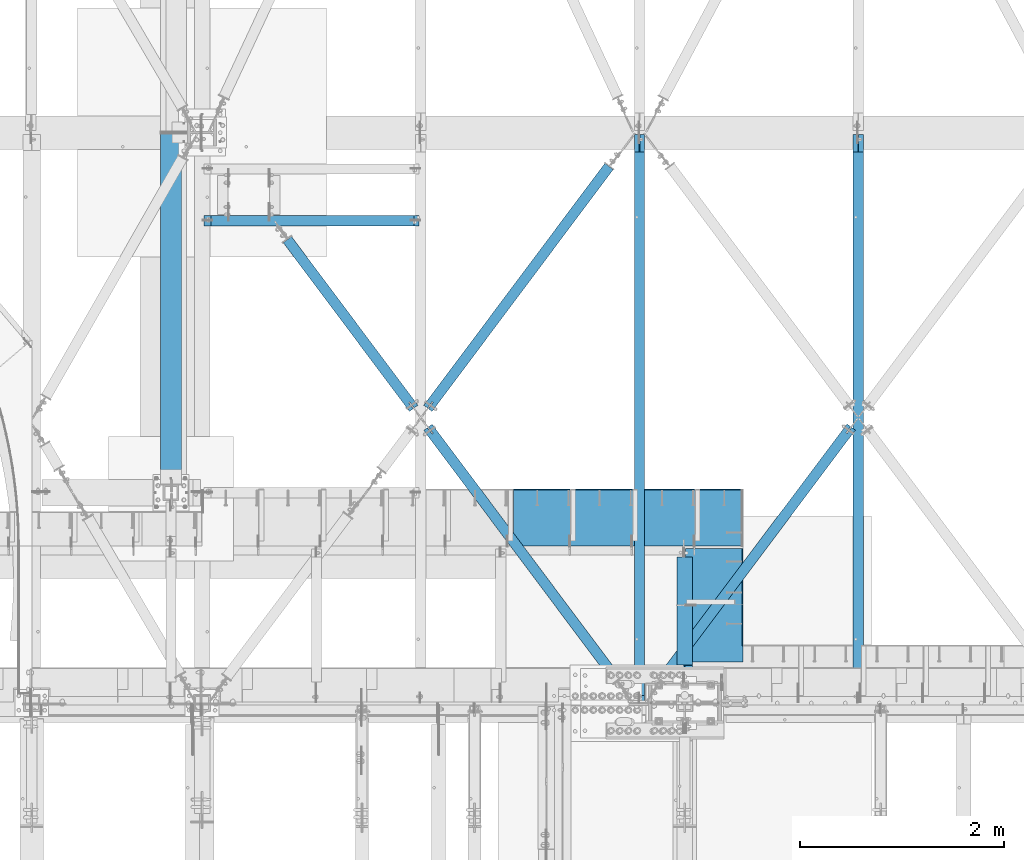
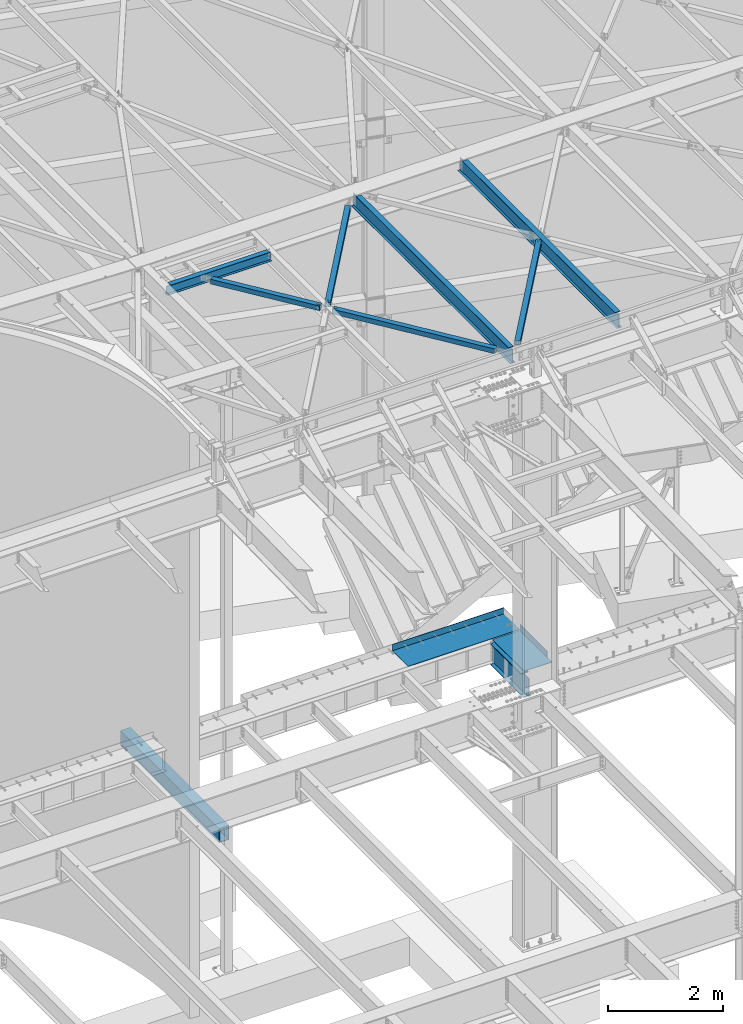
# One storey, part 1151 of 1763: 11 beams, 10 elements without a shape of their own.
"""IFC2X3 building model written with IfcOpenShell, lengths in millimetres."""

import ifcopenshell
import ifcopenshell.guid

model = None  # the IFC model being written
_history = None  # IfcOwnerHistory: only IFC2X3 demands one
_inside = {}  # id of a spatial element -> (the spatial element, [elements in it])
_under = {}  # id of a project, library or spatial element -> (it, [spatial elements below it])
_declared = {}  # id of a project -> (the project, [libraries it declares])
_typed = {}  # id of a type object -> (the type object, [elements of that type])
_made_of = {}  # id of a material, layer set ... -> (it, [elements and type objects made of it])


def new_model(schema):
    """Start an empty IFC model of exactly this schema.

    Asked for "IFC4X3", IfcOpenShell would pick the latest addendum, in which some entities
    have other attributes; the version numbers below select the first issue.
    IFC2X3 requires an IfcOwnerHistory on every rooted entity: one is made here for all.
    """
    global model, _history
    if schema == "IFC4X3":
        model = ifcopenshell.file(schema_version=(4, 3, 0, 0))
    else:
        model = ifcopenshell.file(schema=schema)
    _inside.clear()
    _under.clear()
    _declared.clear()
    _typed.clear()
    _made_of.clear()
    _history = None
    if model.schema == "IFC2X3":
        org = make("IfcOrganization", Name="unknown")
        user = make(
            "IfcPersonAndOrganization",
            ThePerson=make("IfcPerson", FamilyName="unknown"),
            TheOrganization=org,
        )
        app = make(
            "IfcApplication",
            ApplicationDeveloper=org,
            Version="unknown",
            ApplicationFullName="unknown",
            ApplicationIdentifier="unknown",
        )
        _history = make(
            "IfcOwnerHistory",
            OwningUser=user,
            OwningApplication=app,
            ChangeAction="ADDED",
            CreationDate=0,
        )
    return model


def make(cls, **values):
    """One entity of the class cls with the attributes given. An attribute that is None is left unset."""
    return model.create_entity(
        cls, **{name: value for name, value in values.items() if value is not None}
    )


def rooted(cls, **values):
    """An entity with a GlobalId (a new one), such as an element, a storey or a relation."""
    return make(cls, GlobalId=ifcopenshell.guid.new(), OwnerHistory=_history, **values)


def si_unit(unit_type, name, prefix=None):
    """IfcSIUnit, for example si_unit("LENGTHUNIT", "METRE", prefix="MILLI")."""
    return make("IfcSIUnit", UnitType=unit_type, Prefix=prefix, Name=name)


def assignment(units):
    """IfcUnitAssignment: the units of a project."""
    return None if units is None else make("IfcUnitAssignment", Units=units)


def point(xyz):
    """IfcCartesianPoint."""
    return None if xyz is None else make("IfcCartesianPoint", Coordinates=xyz)


def direction(xyz):
    """IfcDirection."""
    return None if xyz is None else make("IfcDirection", DirectionRatios=xyz)


def frame(location, z_axis=None, x_axis=None):
    """IfcAxis2Placement3D, a coordinate frame: its origin and axes. An axis left out is left unset."""
    return make(
        "IfcAxis2Placement3D",
        Location=point(location),
        Axis=direction(z_axis),
        RefDirection=direction(x_axis),
    )


def origin_with_axes():
    """The frame at (0, 0, 0) with the z axis (0, 0, 1) and the x axis (1, 0, 0) written out."""
    return frame((0.0, 0.0, 0.0), z_axis=(0.0, 0.0, 1.0), x_axis=(1.0, 0.0, 0.0))


def place(relative_to, where):
    """IfcLocalPlacement: puts the frame where relative to a parent placement (None: the world)."""
    return make(
        "IfcLocalPlacement", PlacementRelTo=relative_to, RelativePlacement=where
    )


def context(
    kind, dimensions, precision=None, world=None, true_north=None, identifier=None
):
    """IfcGeometricRepresentationContext, for example the 3D "Model" context."""
    return make(
        "IfcGeometricRepresentationContext",
        ContextIdentifier=identifier,
        ContextType=kind,
        CoordinateSpaceDimension=dimensions,
        Precision=precision,
        WorldCoordinateSystem=world,
        TrueNorth=true_north,
    )


def subcontext(parent, identifier, kind, view, scale=None):
    """IfcGeometricRepresentationSubContext, for example "Body" below "Model"."""
    return make(
        "IfcGeometricRepresentationSubContext",
        ContextIdentifier=identifier,
        ContextType=kind,
        ParentContext=parent,
        TargetScale=scale,
        TargetView=view,
    )


def project(units=None, contexts=None):
    """IfcProject with its units and contexts."""
    return rooted(
        "IfcProject",
        Name="project",
        RepresentationContexts=contexts,
        UnitsInContext=assignment(units),
    )


def spatial(cls, under=None, at=None, **own):
    """A site, building, storey or space (cls), placed at a placement, below another one or the project."""
    s = rooted(cls, ObjectPlacement=at, **own)
    if under is not None:
        _under.setdefault(under.id(), (under, []))[1].append(s)
    return s


def faces_of(points, faces, orient=None, outer=None):
    """IfcFace entities. A face is a list of loops; a loop is a list of indices into points, from 0.

    orient and outer hold one flag for each loop. By default every Orientation is true, the
    first loop of a face is its IfcFaceOuterBound and the others are IfcFaceBound.
    """
    made = []
    for i, loops in enumerate(faces):
        bounds = []
        for j, loop in enumerate(loops):
            is_outer = j == 0 if outer is None else outer[i][j]
            bounds.append(
                make(
                    "IfcFaceOuterBound" if is_outer else "IfcFaceBound",
                    Bound=make("IfcPolyLoop", Polygon=[points[k] for k in loop]),
                    Orientation=True if orient is None else orient[i][j],
                )
            )
        made.append(make("IfcFace", Bounds=bounds))
    return made


def faceted_brep(points, faces, orient=None, outer=None, voids=None):
    """IfcFacetedBrep: a solid bounded by flat faces; with voids (closed shells), ...WithVoids."""
    shared = [point(p) for p in points]
    hull = make("IfcClosedShell", CfsFaces=faces_of(shared, faces, orient, outer))
    if voids is None:
        return make("IfcFacetedBrep", Outer=hull)
    return make(
        "IfcFacetedBrepWithVoids",
        Outer=hull,
        Voids=[
            make(cls, CfsFaces=faces_of(shared, fs, o, b)) for cls, fs, o, b in voids
        ],
    )


def shape(context_of_items, identifier, shape_type, items):
    """IfcShapeRepresentation: the items that make up one representation, for example the "Body"."""
    return make(
        "IfcShapeRepresentation",
        ContextOfItems=context_of_items,
        RepresentationIdentifier=identifier,
        RepresentationType=shape_type,
        Items=items,
    )


def material(Name=None, Category=None):
    """IfcMaterial."""
    return make("IfcMaterial", Name=Name, Category=Category)


def made_of(thing, what):
    """Note that an element or type object is made of a material, layer set ...; save() writes the relation."""
    if what is not None:
        _made_of.setdefault(what.id(), (what, []))[1].append(thing)
    return thing


def type_object(cls, material=None, **own):
    """A type object (cls), such as IfcWallType, which elements share."""
    return made_of(rooted(cls, **own), material)


def element(
    cls,
    number,
    at=None,
    inside=None,
    cuts=None,
    type_object=None,
    material=None,
    context=None,
    identifier="Body",
    shape_type=None,
    held_by="IfcProductDefinitionShape",
    body=None,
    shapes=None,
    **own,
):
    """One element of the class cls, such as IfcWall. Its Tag is "e" and its number.

    at: its placement. inside: the storey or other place that contains it. cuts: it is an
    opening in that element (IfcRelVoidsElement). A single representation is given by context,
    identifier, shape_type and body (its items); several are given by shapes. held_by: the class
    of the entity that holds the representations. save() writes the other relations.
    """
    e = rooted(cls, Tag="e%d" % number, ObjectPlacement=at, **own)
    if body is not None:
        shapes = [shape(context, identifier, shape_type, body)]
    if shapes is not None:
        e.Representation = make(held_by, Representations=shapes)
    if inside is not None:
        _inside.setdefault(inside.id(), (inside, []))[1].append(e)
    if cuts is not None:
        rooted(
            "IfcRelVoidsElement", RelatingBuildingElement=cuts, RelatedOpeningElement=e
        )
    if type_object is not None:
        _typed.setdefault(type_object.id(), (type_object, []))[1].append(e)
    return made_of(e, material)


def aggregate(whole, parts):
    """IfcRelAggregates: a whole, such as a stair, and the parts it consists of."""
    return rooted("IfcRelAggregates", RelatingObject=whole, RelatedObjects=parts)


def save(model, path):
    """Write the relations noted so far, then the file.

    IfcRelAggregates (storeys below a building ...), IfcRelContainedInSpatialStructure (elements
    in a storey), IfcRelDefinesByType, IfcRelAssociatesMaterial and IfcRelDeclares: one each for
    every whole, place, type object, material and project.
    """
    for whole, parts in _under.values():
        aggregate(whole, parts)
    for where, things in _inside.values():
        rooted(
            "IfcRelContainedInSpatialStructure",
            RelatedElements=things,
            RelatingStructure=where,
        )
    for kind, things in _typed.values():
        rooted("IfcRelDefinesByType", RelatedObjects=things, RelatingType=kind)
    for what, things in _made_of.values():
        rooted("IfcRelAssociatesMaterial", RelatedObjects=things, RelatingMaterial=what)
    for by, libraries in _declared.values():
        rooted("IfcRelDeclares", RelatingContext=by, RelatedDefinitions=libraries)
    model.write(path)


model = new_model("IFC2X3")

# Units and contexts
model_context = context("Model", 3, precision=1e-05, world=origin_with_axes())
body_context = subcontext(model_context, "Body", "Model", "MODEL_VIEW")
ifc_project = project(units=[si_unit("LENGTHUNIT", "METRE", prefix="MILLI"), si_unit("AREAUNIT", "SQUARE_METRE"), si_unit("VOLUMEUNIT", "CUBIC_METRE"), si_unit("MASSUNIT", "GRAM", prefix="KILO"), si_unit("TIMEUNIT", "SECOND"), si_unit("PLANEANGLEUNIT", "RADIAN"), si_unit("SOLIDANGLEUNIT", "STERADIAN"), si_unit("THERMODYNAMICTEMPERATUREUNIT", "DEGREE_CELSIUS"), si_unit("LUMINOUSINTENSITYUNIT", "LUMEN")], contexts=[model_context])

# Site, building, storey
site_placement = place(None, origin_with_axes())
site = spatial("IfcSite", under=ifc_project, at=site_placement, CompositionType="ELEMENT")
building_placement = place(site_placement, origin_with_axes())
building = spatial("IfcBuilding", under=site, at=building_placement, Name="Undefined", CompositionType="ELEMENT")
storey_placement = place(building_placement, origin_with_axes())
storey = spatial("IfcBuildingStorey", under=building, at=storey_placement, Name="Undefined", CompositionType="ELEMENT", Elevation=0.0)

# Assembly, beam
assembly_1_placement = place(storey_placement, origin_with_axes())
assembly_1 = element("IfcElementAssembly", 1, at=assembly_1_placement, inside=storey, Name="BEAM", AssemblyPlace="NOTDEFINED", PredefinedType="RIGID_FRAME")
ifc_material_1 = material(Name="STEEL/A992")
beam_type_1 = type_object("IfcBeamType", Name="W8X10", PredefinedType="NOTDEFINED")
beam_1_placement = place(assembly_1_placement, frame((-39672.2896174484, 56838.8499999993, 12345.9875), z_axis=(0.0, 0.0, 1.0), x_axis=(1.0, 0.0, 0.0)))
beam_1 = element("IfcBeam", 2, at=beam_1_placement, type_object=beam_type_1, material=ifc_material_1, Name="BEAM", ObjectType="W8X10", context=body_context, shape_type="Brep", body=[
    faceted_brep([(2073.27499999999, -50.8000000000029, 100.012500000001), (2073.27499999999, -50.8000000000029, 95.25), (2073.27499999999, -2.38124999999854, 95.25), (2073.27499999999, -2.38124999999854, 93.4024995803829), (2073.27499999999, 2.38124999999854, 93.4024995803829), (2073.27499999999, 2.38124999999854, 95.25), (2073.27499999999, 50.8000000000029, 95.25), (2073.27499999999, 50.8000000000029, 100.012500000001), (2074.24172992259, -2.38124999999854, 88.5424200623365), (2074.24172992259, 2.38124999999854, 88.5424200623365), (2076.99474382306, -2.38124999999854, 84.4222435941829), (2076.99474382306, 2.38124999999854, 84.4222435941829), (2081.11492029121, -2.38124999999854, 81.6692296937053), (2081.11492029121, 2.38124999999854, 81.6692296937053), (2085.97499980926, -2.38124999999854, 80.7024997711178), (2085.97499980926, 2.38124999999854, 80.7024997711178), (2124.075, -2.38124999999854, 80.7024997711178), (2124.075, 2.38124999999854, 80.7024997711178), (88.8999969557553, -50.8000000000029, 100.012500000001), (88.8999969557553, 50.8000000000029, 100.012500000001), (88.8999969557553, 50.8000000000029, 95.25), (88.8999969557553, 2.38124999999854, 95.25), (88.8999969557553, 2.38124999999854, 84.1374998092651), (88.8999969557553, -2.38124999999854, 84.1374998092651), (88.8999969557553, -2.38124999999854, 95.25), (88.8999969557553, -50.8000000000029, 95.25), (87.9332670331642, 2.38124999999854, 79.2774202912187), (87.9332670331642, -2.38124999999854, 79.2774202912187), (85.1802531326903, 2.38124999999854, 75.1572438230651), (85.1802531326903, -2.38124999999854, 75.1572438230651), (81.0600766645366, 2.38124999999854, 72.4042299225875), (81.0600766645366, -2.38124999999854, 72.4042299225875), (76.1999971464902, 2.38124999999854, 71.4375), (76.1999971464902, -2.38124999999854, 71.4375), (16.6687500075204, 2.38124999999854, 71.4375), (16.6687500075204, -2.38124999999854, 71.4375), (16.6687500075204, 2.38124999999854, -95.25), (16.6687500075204, 50.8000000000029, -95.25), (16.6687500075204, 50.8000000000029, -100.012500000001), (16.6687500075204, -50.8000000000029, -100.012500000001), (16.6687500075204, -50.8000000000029, -95.25), (16.6687500075204, -2.38124999999854, -95.25), (2124.075, 2.38124999999854, -95.25), (2124.075, 50.8000000000029, -95.25), (2124.075, 50.8000000000029, -100.012500000001), (2124.075, -50.8000000000029, -100.012500000001), (2124.075, -50.8000000000029, -95.25), (2124.075, -2.38124999999854, -95.25)], [[[0, 1, 2, 3, 4, 5, 6, 7]], [[8, 9, 4, 3]], [[10, 11, 9, 8]], [[12, 13, 11, 10]], [[14, 15, 13, 12]], [[16, 17, 15, 14]], [[18, 19, 20, 21, 22, 23, 24, 25]], [[23, 22, 26, 27]], [[27, 26, 28, 29]], [[29, 28, 30, 31]], [[31, 30, 32, 33]], [[33, 32, 34, 35]], [[36, 37, 38, 39, 40, 41, 35, 34]], [[37, 36, 42, 43]], [[38, 37, 43, 44]], [[39, 38, 44, 45]], [[40, 39, 45, 46]], [[41, 40, 46, 47]], [[12, 10, 8, 3, 2, 24, 23, 27, 29, 31, 33, 35, 41, 47, 16, 14]], [[25, 24, 2, 1]], [[18, 25, 1, 0]], [[19, 18, 0, 7]], [[20, 19, 7, 6]], [[21, 20, 6, 5]], [[42, 36, 34, 32, 30, 28, 26, 22, 21, 5, 4, 9, 11, 13, 15, 17]], [[47, 46, 45, 44, 43, 42, 17, 16]]]),
])
aggregate(assembly_1, [beam_1])

assembly_2_placement = place(storey_placement, origin_with_axes())
assembly_2 = element("IfcElementAssembly", 3, at=assembly_2_placement, inside=storey, Name="H. BRACE", AssemblyPlace="NOTDEFINED", PredefinedType="RIGID_FRAME")
ifc_material_2 = material()
beam_type_2 = type_object("IfcBeamType", Name="HSS4X4X3/8", PredefinedType="NOTDEFINED")
beam_2_placement = place(assembly_2_placement, frame((-37532.3396174715, 54911.6249997678, 12371.3875), z_axis=(0.0, 0.0, 1.0), x_axis=(-0.599271154042197, 0.800546116056367, 0.0)))
beam_2 = element("IfcBeam", 4, at=beam_2_placement, type_object=beam_type_2, material=ifc_material_2, Name="H. BRACE", ObjectType="HSS4X4X3/8", context=body_context, shape_type="Brep", body=[
    faceted_brep([(115.54492887533, 6.35000628506759, 50.7999999999993), (115.54492887533, 6.35000628506759, 41.2749999999996), (192.63464721787, 6.35000000986702, 41.2749999999996), (192.63464721787, 6.35000000986702, 50.7999999999993), (192.634646184073, -6.34999999016281, 50.7999999999993), (192.634646184073, -6.34999999016281, 41.2749999999996), (115.544928875344, -6.34999371496588, 41.2749999999996), (115.544928875344, -6.34999371496588, 50.7999999999993), (115.54492887533, 6.35000628506759, -41.2749999999996), (115.54492887533, 6.35000628506759, -50.7999999999993), (192.63464721787, 6.35000000986702, -50.7999999999993), (192.63464721787, 6.35000000986702, -41.2749999999996), (192.634646184073, -6.34999999016281, -41.2749999999996), (192.634646184073, -6.34999999016281, -50.7999999999993), (115.544928875344, -6.34999371496588, -50.7999999999993), (115.544928875344, -6.34999371496588, -41.2749999999996), (115.544928544976, -41.2750000003798, -41.2749999999996), (115.544928544976, -41.2750000003798, 41.2749999999996), (2179.00881947795, -41.2749999953026, 41.2749999999996), (2179.00881947795, -41.2749999953026, -41.2749999999996), (115.544928544969, 50.7999999998938, -50.7999999999993), (2179.00881947795, 50.8000000049637, -50.7999999999993), (2179.00881947795, -50.7999999953367, -50.7999999999993), (115.544928544976, -50.8000000004031, -50.7999999999993), (115.544928544976, -50.8000000004031, 50.7999999999993), (2179.00881947795, -50.7999999953367, 50.7999999999993), (115.544928544965, 41.2749999998705, 41.2749999999996), (2179.00881947795, 41.2750000049368, 41.2749999999996), (115.544928544965, 41.2749999998705, -41.2749999999996), (2179.00881947795, 41.2750000049368, -41.2749999999996), (2179.00881947795, 50.8000000049637, 50.7999999999993), (115.544928544969, 50.7999999998938, 50.7999999999993)], [[[0, 1, 2, 3]], [[4, 5, 6, 7]], [[3, 2, 5, 4]], [[8, 9, 10, 11]], [[12, 13, 14, 15]], [[11, 10, 13, 12]], [[16, 17, 18, 19]], [[9, 20, 21, 22, 23, 14, 13, 10]], [[24, 23, 22, 25]], [[17, 16, 15, 14, 23, 24, 7, 6]], [[1, 26, 27, 18, 17, 6, 5, 2]], [[26, 28, 29, 27]], [[25, 22, 21, 30], [18, 27, 29, 19]], [[20, 31, 30, 21]], [[24, 25, 30, 31, 0, 3, 4, 7]], [[31, 20, 9, 8, 28, 26, 1, 0]], [[16, 19, 29, 28, 8, 11, 12, 15]]]),
])
aggregate(assembly_2, [beam_2])

assembly_3_placement = place(storey_placement, origin_with_axes())
assembly_3 = element("IfcElementAssembly", 5, at=assembly_3_placement, inside=storey, Name="H. BRACE", AssemblyPlace="NOTDEFINED", PredefinedType="RIGID_FRAME")
beam_3_placement = place(assembly_3_placement, frame((-33252.4396174507, 54913.6789185365, 12371.3875), z_axis=(0.0, 0.0, 1.0), x_axis=(-0.600137979714526, -0.799896496619511, 0.0)))
beam_3 = element("IfcBeam", 6, at=beam_3_placement, type_object=beam_type_2, material=ifc_material_2, Name="H. BRACE", ObjectType="HSS4X4X3/8", context=body_context, shape_type="Brep", body=[
    faceted_brep([(115.323049640105, 6.35036732612934, 50.7999999999993), (115.323049640105, 6.35036732612934, 41.2749999999996), (192.613788202219, 6.35004939841019, 41.2749999999996), (192.613788202219, 6.35004939841019, 50.7999999999993), (192.613735962041, -6.34995060151414, 50.7999999999993), (192.613735962041, -6.34995060151414, 41.2749999999996), (115.323049640094, -6.34963267402054, 41.2749999999996), (115.323049640094, -6.34963267402054, 50.7999999999993), (115.323049640105, 6.35036732612934, -41.2749999999996), (115.323049640105, 6.35036732612934, -50.7999999999993), (192.613788202219, 6.35004939841019, -50.7999999999993), (192.613788202219, 6.35004939841019, -41.2749999999996), (192.613735962041, -6.34995060151414, -41.2749999999996), (192.613735962041, -6.34995060151414, -50.7999999999993), (115.323049640094, -6.34963267402054, -50.7999999999993), (115.323049640094, -6.34963267402054, -41.2749999999996), (115.323049640101, -41.2750000002925, -41.2749999999996), (115.323049640101, -41.2750000002925, 41.2749999999996), (3211.35244293956, -41.2750000086453, 41.2749999999996), (3211.35244293956, -41.2750000086453, -41.2749999999996), (115.323049640101, 50.7999999996464, -50.7999999999993), (3211.35244293955, 50.7999999912863, -50.7999999999993), (3211.35244293955, -50.8000000086395, -50.7999999999993), (115.323049640101, -50.8000000002867, -50.7999999999993), (115.323049640101, -50.8000000002867, 50.7999999999993), (3211.35244293955, -50.8000000086395, 50.7999999999993), (115.323049640101, 41.2749999996522, 41.2749999999996), (3211.35244293955, 41.2749999912994, 41.2749999999996), (115.323049640101, 41.2749999996522, -41.2749999999996), (3211.35244293955, 41.2749999912994, -41.2749999999996), (3211.35244293955, 50.7999999912863, 50.7999999999993), (115.323049640101, 50.7999999996464, 50.7999999999993)], [[[0, 1, 2, 3]], [[4, 5, 6, 7]], [[3, 2, 5, 4]], [[8, 9, 10, 11]], [[12, 13, 14, 15]], [[11, 10, 13, 12]], [[16, 17, 18, 19]], [[9, 20, 21, 22, 23, 14, 13, 10]], [[24, 23, 22, 25]], [[17, 16, 15, 14, 23, 24, 7, 6]], [[1, 26, 27, 18, 17, 6, 5, 2]], [[26, 28, 29, 27]], [[25, 22, 21, 30], [18, 27, 29, 19]], [[20, 31, 30, 21]], [[24, 25, 30, 31, 0, 3, 4, 7]], [[31, 20, 9, 8, 28, 26, 1, 0]], [[16, 19, 29, 28, 8, 11, 12, 15]]]),
])
aggregate(assembly_3, [beam_3])

assembly_4_placement = place(storey_placement, origin_with_axes())
assembly_4 = element("IfcElementAssembly", 7, at=assembly_4_placement, inside=storey, Name="H. BRACE", AssemblyPlace="NOTDEFINED", PredefinedType="RIGID_FRAME")
beam_4_placement = place(assembly_4_placement, frame((-35443.1896206415, 57702.4499982766, 12371.3875), z_axis=(0.0, 0.0, 1.0), x_axis=(-0.599271154042197, -0.800546116056367, 0.0)))
beam_4 = element("IfcBeam", 8, at=beam_4_placement, type_object=beam_type_2, material=ifc_material_2, Name="H. BRACE", ObjectType="HSS4X4X3/8", context=body_context, shape_type="Brep", body=[
    faceted_brep([(3370.60651739793, 6.35217274886236, 50.7999999999993), (3293.52321707223, 6.35001054574241, 50.7999999999993), (3293.52321707223, 6.35001054574241, 41.2749999999996), (3370.60651739793, 6.35217274886236, 41.2749999999996), (3293.52357330995, -6.34998944934341, 50.7999999999993), (3293.52357330995, -6.34998944934341, 41.2749999999996), (3370.60651739793, -6.34782725620607, 50.7999999999993), (3370.60651739793, -6.34782725620607, 41.2749999999996), (3370.60651739793, 6.35217274886236, -41.2749999999996), (3293.52321707223, 6.35001054574241, -41.2749999999996), (3293.52321707223, 6.35001054574241, -50.7999999999993), (3370.60651739793, 6.35217274886236, -50.7999999999993), (3293.52357330995, -6.34998944934341, -41.2749999999996), (3293.52357330995, -6.34998944934341, -50.7999999999993), (3370.60651739793, -6.34782725620607, -41.2749999999996), (3370.60651739793, -6.34782725620607, -50.7999999999993), (413.146953942767, 41.2749999992084, 41.2749999999996), (413.146953942767, 41.2749999992084, -41.2749999999996), (3370.60651739793, 41.2749999926746, -41.2749999999996), (3370.60651739793, 41.2749999926746, 41.2749999999996), (3370.60651739793, -41.2750000075612, 41.2749999999996), (413.146953942756, -41.2750000010274, 41.2749999999996), (413.146953942756, -41.2750000010274, -41.2749999999996), (3370.60651739793, -41.2750000075612, -41.2749999999996), (413.146953942764, -50.8000000010579, -50.7999999999993), (413.146953942764, -50.8000000010579, 50.7999999999993), (413.14695394276, 50.7999999992317, 50.7999999999993), (413.14695394276, 50.7999999992317, -50.7999999999993), (3370.60651739793, 50.7999999926978, 50.7999999999993), (3370.60651739793, 50.7999999926978, -50.7999999999993), (3370.60651739793, -50.8000000075917, -50.7999999999993), (3370.60651739793, -50.8000000075917, 50.7999999999993)], [[[0, 1, 2, 3]], [[4, 5, 2, 1]], [[6, 7, 5, 4]], [[8, 9, 10, 11]], [[12, 13, 10, 9]], [[14, 15, 13, 12]], [[16, 17, 18, 19]], [[20, 21, 16, 19, 3, 2, 5, 7]], [[22, 21, 20, 23]], [[9, 8, 18, 17, 22, 23, 14, 12]], [[24, 25, 26, 27], [16, 21, 22, 17]], [[27, 26, 28, 29]], [[19, 18, 8, 11, 29, 28, 0, 3]], [[30, 24, 27, 29, 11, 10, 13, 15]], [[25, 24, 30, 31]], [[1, 0, 28, 26, 25, 31, 6, 4]], [[31, 30, 15, 14, 23, 20, 7, 6]]]),
])
aggregate(assembly_4, [beam_4])

assembly_5_placement = place(storey_placement, origin_with_axes())
assembly_5 = element("IfcElementAssembly", 9, at=assembly_5_placement, inside=storey, Name="H. BRACE", AssemblyPlace="NOTDEFINED", PredefinedType="RIGID_FRAME")
beam_5_placement = place(assembly_5_placement, frame((-35443.1896174837, 52120.8000004499, 12371.3875), z_axis=(0.0, 0.0, 1.0), x_axis=(-0.599271154042197, 0.800546116056367, 0.0)))
beam_5 = element("IfcBeam", 10, at=beam_5_placement, type_object=beam_type_2, material=ifc_material_2, Name="H. BRACE", ObjectType="HSS4X4X3/8", context=body_context, shape_type="Brep", body=[
    faceted_brep([(3370.60651701657, 6.34999381892521, 50.7999999999993), (3293.51679972227, 6.35000009411851, 50.7999999999993), (3293.51679972227, 6.35000009411851, 41.2749999999996), (3370.60651701657, 6.34999381892521, 41.2749999999996), (3293.51679868849, -6.34999990591132, 50.7999999999993), (3293.51679868849, -6.34999990591132, 41.2749999999996), (3370.60651701657, -6.35000618111917, 50.7999999999993), (3370.60651701657, -6.35000618111917, 41.2749999999996), (3370.60651701657, 6.34999381892521, -41.2749999999996), (3293.51679972227, 6.35000009411851, -41.2749999999996), (3293.51679972227, 6.35000009411851, -50.7999999999993), (3370.60651701657, 6.34999381892521, -50.7999999999993), (3293.51679868849, -6.34999990591132, -41.2749999999996), (3293.51679868849, -6.34999990591132, -50.7999999999993), (3370.60651701657, -6.35000618111917, -41.2749999999996), (3370.60651701657, -6.35000618111917, -50.7999999999993), (280.170548871072, 41.2750000007491, 41.2749999999996), (280.170548871072, 41.2750000007491, -41.2749999999996), (3370.60651739793, 41.2749999926746, -41.2749999999996), (3370.60651739793, 41.2749999926746, 41.2749999999996), (3370.60651739793, -41.2750000075612, 41.2749999999996), (280.170548871072, -41.274999999494, 41.2749999999996), (280.170548871072, -41.274999999494, -41.2749999999996), (3370.60651739793, -41.2750000075612, -41.2749999999996), (280.17054887108, -50.7999999995172, -50.7999999999993), (280.17054887108, -50.7999999995172, 50.7999999999993), (280.170548871072, 50.8000000007723, 50.7999999999993), (280.170548871072, 50.8000000007723, -50.7999999999993), (3370.60651739793, 50.7999999926978, 50.7999999999993), (3370.60651739793, 50.7999999926978, -50.7999999999993), (3370.60651739793, -50.8000000075917, -50.7999999999993), (3370.60651739793, -50.8000000075917, 50.7999999999993)], [[[0, 1, 2, 3]], [[4, 5, 2, 1]], [[6, 7, 5, 4]], [[8, 9, 10, 11]], [[12, 13, 10, 9]], [[14, 15, 13, 12]], [[16, 17, 18, 19]], [[20, 21, 16, 19, 3, 2, 5, 7]], [[22, 21, 20, 23]], [[9, 8, 18, 17, 22, 23, 14, 12]], [[24, 25, 26, 27], [16, 21, 22, 17]], [[27, 26, 28, 29]], [[19, 18, 8, 11, 29, 28, 0, 3]], [[30, 24, 27, 29, 11, 10, 13, 15]], [[25, 24, 30, 31]], [[1, 0, 28, 26, 25, 31, 6, 4]], [[31, 30, 15, 14, 23, 20, 7, 6]]]),
])
aggregate(assembly_5, [beam_5])

assembly_6_placement = place(storey_placement, origin_with_axes())
assembly_6 = element("IfcElementAssembly", 11, at=assembly_6_placement, inside=storey, Name="BEAM", AssemblyPlace="NOTDEFINED", PredefinedType="RIGID_FRAME")
ifc_material_3 = material(Name="STEEL/A36")
beam_type_3 = type_object("IfcBeamType", PredefinedType="NOTDEFINED")
beam_6_placement = place(assembly_6_placement, frame((-34943.4872736984, 53076.4799995422, 5199.0625), z_axis=(0.0, -1.0, 0.0), x_axis=(1.0, 0.0, 0.0)))
beam_6 = element("IfcBeam", 12, at=beam_6_placement, type_object=beam_type_3, material=ifc_material_3, Name="BENT PLATE", context=body_context, shape_type="Brep", body=[
    faceted_brep([(561.975402832039, 134.937496948242, 396.910991792152), (552.450402832088, 134.937526078659, 396.910561852666), (552.450004716316, 4.76249999999982, 396.910562799247), (561.975004737265, 4.76933441718575, 396.910992738674), (561.975004737265, 4.76933441725305, 555.625), (552.450004716316, 4.76249999999982, 555.625), (0.0, -4.76249999999982, -555.625), (0.0, -4.76249999999982, 555.625), (0.0, 4.76249999999982, 555.625), (0.0, 4.76249999999982, -555.625), (561.974975585945, -4.76249999999982, -555.625), (552.450004716316, 4.76249999999982, -555.625), (552.450402832088, 134.937526078659, -555.625), (561.975402832039, 134.937496948242, -555.625), (561.974975585945, -4.76249999999982, 555.625), (14.5130368310492, 4.76249999999982, 555.625)], [[[0, 1, 2, 3]], [[4, 3, 2, 5]], [[6, 7, 8, 9]], [[10, 6, 9, 11, 12, 13]], [[7, 6, 10, 14]], [[15, 8, 7, 14, 4, 5]], [[9, 8, 15, 5, 2, 11]], [[12, 11, 2, 1]], [[13, 12, 1, 0]], [[14, 10, 13, 0, 3, 4]]]),
])

assembly_7_placement = place(storey_placement, origin_with_axes())
assembly_7 = element("IfcElementAssembly", 13, at=assembly_7_placement, inside=storey, Name="BEAM", AssemblyPlace="NOTDEFINED", PredefinedType="RIGID_FRAME")
beam_type_4 = type_object("IfcBeamType", PredefinedType="NOTDEFINED")
beam_7_placement = place(assembly_7_placement, frame((-35502.7211174484, 53657.5, 5199.0625), z_axis=(1.0, 0.0, 0.0), x_axis=(0.0, 1.0, 0.0)))
beam_7 = element("IfcBeam", 14, at=beam_7_placement, type_object=beam_type_4, material=ifc_material_3, Name="BENT PLATE", context=body_context, shape_type="Brep", body=[
    faceted_brep([(0.0, -4.76249999999982, -1121.5685), (0.0, -4.76249999999982, 1121.5685), (0.0, 4.76249999999982, 1121.5685), (0.0, 4.76249999999982, -1121.5685), (546.100000000006, 4.76249999999982, 1121.5685), (546.100000000006, 4.76249999999982, -1121.5685), (555.625, -4.76249999999982, -1121.5685), (555.625, -4.76249999999982, 1121.5685), (546.100000000006, 134.937496948242, 1121.5685), (546.100000000006, 134.937496948242, -1121.5685), (555.625, 134.937496948242, 1121.5685), (555.625, 134.937496948242, -1121.5685)], [[[0, 1, 2, 3]], [[3, 2, 4, 5]], [[1, 0, 6, 7]], [[5, 4, 8, 9]], [[4, 2, 1, 7, 10, 8]], [[7, 6, 11, 10]], [[6, 0, 3, 5, 9, 11]], [[10, 11, 9, 8]]]),
])
aggregate(assembly_7, [beam_7])

assembly_8_placement = place(storey_placement, origin_with_axes())
assembly_8 = element("IfcElementAssembly", 15, at=assembly_8_placement, inside=storey, Name="BEAM", AssemblyPlace="NOTDEFINED", PredefinedType="RIGID_FRAME")
beam_type_5 = type_object("IfcBeamType", Name="W12X16", PredefinedType="NOTDEFINED")
beam_8_placement = place(assembly_8_placement, frame((-33252.4396174484, 52120.8, 12293.6), z_axis=(0.0, 0.0, 1.0), x_axis=(0.0, 1.0, 0.0)))
beam_8 = element("IfcBeam", 16, at=beam_8_placement, type_object=beam_type_5, material=ifc_material_1, Name="BEAM", ObjectType="W12X16", context=body_context, shape_type="Brep", body=[
    faceted_brep([(63.5000001907174, -3.17499999999927, 126.740001678467), (63.5000001907174, 3.17499999999927, 126.740001678467), (15.8749999999854, 3.17499999999927, 126.740001678467), (15.8749999999854, -3.17499999999927, 126.740001678467), (68.3600797087638, -3.17499999999927, 127.706731601054), (68.3600797087638, 3.17499999999927, 127.706731601054), (72.4802561769175, -3.17499999999927, 130.459745501532), (72.4802561769175, 3.17499999999927, 130.459745501532), (75.2332700773914, -3.17499999999927, 134.579921969686), (75.2332700773914, 3.17499999999927, 134.579921969686), (76.1999999999825, -3.17499999999927, 139.440001487732), (76.1999999999825, 3.17499999999927, 139.440001487732), (76.1999999999825, -50.7999999999993, 152.4), (76.1999999999825, 50.7999999999993, 152.4), (76.1999999999825, 50.7999999999993, 146.049999999999), (76.1999999999825, 3.17499999999927, 146.049999999999), (76.1999999999825, -3.17499999999927, 146.049999999999), (76.1999999999825, -50.7999999999993, 146.049999999999), (15.8749999999854, -3.17499999999927, -146.049999999999), (15.8749999999854, -50.7999999999993, -146.049999999999), (5561.01249999999, -50.7999999999993, -146.049999999999), (5561.01249999999, -3.17499999999927, -146.049999999999), (15.8749999999854, -50.7999999999993, -152.4), (5561.01249999999, -50.7999999999993, -152.4), (15.8749999999854, 50.7999999999993, -152.4), (5561.01249999999, 50.7999999999993, -152.4), (15.8749999999854, 50.7999999999993, -146.049999999999), (5561.01249999999, 50.7999999999993, -146.049999999999), (15.8749999999854, 3.17499999999927, -146.049999999999), (5561.01249999999, 3.17499999999927, -146.049999999999), (5561.01249999999, 3.17499999999927, 114.040001678466), (5561.01249999999, -3.17499999999927, 114.040001678466), (5402.26249980926, 3.17499999999927, 114.040001678466), (5402.26249980926, -3.17499999999927, 114.040001678466), (5397.40242029121, 3.17499999999927, 115.006731601054), (5397.40242029121, -3.17499999999927, 115.006731601054), (5393.28224382306, 3.17499999999927, 117.759745501531), (5393.28224382306, -3.17499999999927, 117.759745501531), (5390.52922992258, 3.17499999999927, 121.879921969685), (5390.52922992258, -3.17499999999927, 121.879921969685), (5389.56249999999, 3.17499999999927, 126.740001487731), (5389.56249999999, -3.17499999999927, 126.740001487731), (5389.56249999999, -50.7999999999993, 152.4), (5389.56249999999, -50.7999999999993, 146.049999999999), (5389.56249999999, -3.17499999999927, 146.049999999999), (5389.56249999999, 3.17499999999927, 146.049999999999), (5389.56249999999, 50.7999999999993, 146.049999999999), (5389.56249999999, 50.7999999999993, 152.4)], [[[0, 1, 2, 3]], [[4, 5, 1, 0]], [[6, 7, 5, 4]], [[8, 9, 7, 6]], [[10, 11, 9, 8]], [[12, 13, 14, 15, 11, 10, 16, 17]], [[18, 19, 20, 21]], [[19, 22, 23, 20]], [[22, 24, 25, 23]], [[24, 26, 27, 25]], [[26, 28, 29, 27]], [[21, 20, 23, 25, 27, 29, 30, 31]], [[31, 30, 32, 33]], [[33, 32, 34, 35]], [[35, 34, 36, 37]], [[37, 36, 38, 39]], [[39, 38, 40, 41]], [[42, 43, 44, 41, 40, 45, 46, 47]], [[43, 42, 12, 17]], [[44, 43, 17, 16]], [[8, 6, 4, 0, 3, 18, 21, 31, 33, 35, 37, 39, 41, 44, 16, 10]], [[28, 26, 24, 22, 19, 18, 3, 2]], [[45, 40, 38, 36, 34, 32, 30, 29, 28, 2, 1, 5, 7, 9, 11, 15]], [[46, 45, 15, 14]], [[47, 46, 14, 13]], [[42, 47, 13, 12]]]),
])
aggregate(assembly_8, [beam_8])

assembly_9_placement = place(storey_placement, origin_with_axes())
assembly_9 = element("IfcElementAssembly", 17, at=assembly_9_placement, inside=storey, Name="BEAM", AssemblyPlace="NOTDEFINED", PredefinedType="RIGID_FRAME")
beam_9_placement = place(assembly_9_placement, frame((-35392.3896174484, 52120.8, 12293.6), z_axis=(0.0, 0.0, 1.0), x_axis=(0.0, 1.0, 0.0)))
beam_9 = element("IfcBeam", 18, at=beam_9_placement, type_object=beam_type_5, material=ifc_material_1, Name="BEAM", ObjectType="W12X16", context=body_context, shape_type="Brep", body=[
    faceted_brep([(63.5000001907174, -3.17499999999927, 126.740001678467), (63.5000001907174, 3.17499999999927, 126.740001678467), (15.8749999999854, 3.17499999999927, 126.740001678467), (15.8749999999854, -3.17499999999927, 126.740001678467), (68.3600797087638, -3.17499999999927, 127.706731601054), (68.3600797087638, 3.17499999999927, 127.706731601054), (72.4802561769175, -3.17499999999927, 130.459745501532), (72.4802561769175, 3.17499999999927, 130.459745501532), (75.2332700773914, -3.17499999999927, 134.579921969686), (75.2332700773914, 3.17499999999927, 134.579921969686), (76.1999999999825, -3.17499999999927, 139.440001487732), (76.1999999999825, 3.17499999999927, 139.440001487732), (76.1999999999825, -50.7999999999993, 152.4), (76.1999999999825, 50.7999999999993, 152.4), (76.1999999999825, 50.7999999999993, 146.049999999999), (76.1999999999825, 3.17499999999927, 146.049999999999), (76.1999999999825, -3.17499999999927, 146.049999999999), (76.1999999999825, -50.7999999999993, 146.049999999999), (15.8749999999854, -3.17499999999927, -146.049999999999), (15.8749999999854, -50.7999999999993, -146.049999999999), (5561.01249999999, -50.7999999999993, -146.049999999999), (5561.01249999999, -3.17499999999927, -146.049999999999), (15.8749999999854, -50.7999999999993, -152.4), (5561.01249999999, -50.7999999999993, -152.4), (15.8749999999854, 50.7999999999993, -152.4), (5561.01249999999, 50.7999999999993, -152.4), (15.8749999999854, 50.7999999999993, -146.049999999999), (5561.01249999999, 50.7999999999993, -146.049999999999), (15.8749999999854, 3.17499999999927, -146.049999999999), (5561.01249999999, 3.17499999999927, -146.049999999999), (5561.01249999999, 3.17499999999927, 114.040001678466), (5561.01249999999, -3.17499999999927, 114.040001678466), (5402.26249980926, 3.17499999999927, 114.040001678466), (5402.26249980926, -3.17499999999927, 114.040001678466), (5397.40242029121, 3.17499999999927, 115.006731601054), (5397.40242029121, -3.17499999999927, 115.006731601054), (5393.28224382306, 3.17499999999927, 117.759745501531), (5393.28224382306, -3.17499999999927, 117.759745501531), (5390.52922992258, 3.17499999999927, 121.879921969685), (5390.52922992258, -3.17499999999927, 121.879921969685), (5389.56249999999, 3.17499999999927, 126.740001487731), (5389.56249999999, -3.17499999999927, 126.740001487731), (5389.56249999999, -50.7999999999993, 152.4), (5389.56249999999, -50.7999999999993, 146.049999999999), (5389.56249999999, -3.17499999999927, 146.049999999999), (5389.56249999999, 3.17499999999927, 146.049999999999), (5389.56249999999, 50.7999999999993, 146.049999999999), (5389.56249999999, 50.7999999999993, 152.4)], [[[0, 1, 2, 3]], [[4, 5, 1, 0]], [[6, 7, 5, 4]], [[8, 9, 7, 6]], [[10, 11, 9, 8]], [[12, 13, 14, 15, 11, 10, 16, 17]], [[18, 19, 20, 21]], [[19, 22, 23, 20]], [[22, 24, 25, 23]], [[24, 26, 27, 25]], [[26, 28, 29, 27]], [[21, 20, 23, 25, 27, 29, 30, 31]], [[31, 30, 32, 33]], [[33, 32, 34, 35]], [[35, 34, 36, 37]], [[37, 36, 38, 39]], [[39, 38, 40, 41]], [[42, 43, 44, 41, 40, 45, 46, 47]], [[43, 42, 12, 17]], [[44, 43, 17, 16]], [[8, 6, 4, 0, 3, 18, 21, 31, 33, 35, 37, 39, 41, 44, 16, 10]], [[28, 26, 24, 22, 19, 18, 3, 2]], [[45, 40, 38, 36, 34, 32, 30, 29, 28, 2, 1, 5, 7, 9, 11, 15]], [[46, 45, 15, 14]], [[47, 46, 14, 13]], [[42, 47, 13, 12]]]),
])
aggregate(assembly_9, [beam_9])

# Beam
beam_type_6 = type_object("IfcBeamType", Name="W18X40", PredefinedType="NOTDEFINED")
beam_10_placement = place(assembly_6_placement, frame((-34949.8372736984, 52120.8, 4967.2875), z_axis=(0.0, 0.0, 1.0), x_axis=(0.0, 1.0, 0.0)))
beam_10 = element("IfcBeam", 19, at=beam_10_placement, type_object=beam_type_6, material=ifc_material_1, Name="BEAM", ObjectType="W18X40", context=body_context, shape_type="Brep", body=[
    faceted_brep([(372.457576987363, -76.1999999999971, 227.0125), (372.457576987363, 76.1999999999971, 227.0125), (365.125015724399, 76.1999999999971, 214.3125), (365.125015724399, 3.96875, 214.3125), (364.895800503073, 3.96875, 213.91549911499), (364.895800503073, -3.96875, 213.91549911499), (365.125015724399, -3.96875, 214.3125), (365.125015724399, -76.1999999999971, 214.3125), (390.524999999994, -3.96875, 213.91549911499), (390.524999999994, 3.96875, 213.91549911499), (411.734104070623, 3.96875, 204.211830867132), (411.734104070623, -3.96875, 204.211830867132), (414.772019765907, 3.96875, 201.276913128712), (414.772019765907, -3.96875, 201.276913128712), (415.296624418486, 3.96875, 197.085557278698), (415.296624418486, -3.96875, 197.085557278698), (413.075780883453, 3.96875, 193.492434974088), (413.075780883453, -3.96875, 193.492434974088), (409.092210673014, 3.96875, 192.0875), (409.092210673014, -3.96875, 192.0875), (209.549999999996, 3.96875, 192.0875), (209.549999999996, -3.96875, 192.0875), (209.549999999996, 3.96875, -192.0875), (209.549999999996, -3.96875, -192.0875), (299.408211039226, 3.96875, -192.0875), (299.408211039226, -3.96875, -192.0875), (303.391781249666, 3.96875, -193.492434974089), (303.391781249666, -3.96875, -193.492434974089), (305.612624784699, 3.96875, -197.085557278698), (305.612624784699, -3.96875, -197.085557278698), (305.08802013212, 3.96875, -201.276913128712), (305.08802013212, -3.96875, -201.276913128712), (302.050104436836, 3.96875, -204.211830867132), (302.050104436836, -3.96875, -204.211830867132), (280.841000366207, 3.96875, -213.91549911499), (280.841000366207, -3.96875, -213.91549911499), (1431.13125, 76.1999999999971, -214.3125), (1431.13125, 76.1999999999971, -227.0125), (273.050407506562, 76.1999999999971, -227.0125), (280.382595789953, 76.1999999999971, -214.3125), (1431.13125, -76.1999999999971, -227.0125), (273.050407506562, -76.1999999999971, -227.0125), (1431.13125, -76.1999999999971, -214.3125), (280.382595789953, -76.1999999999971, -214.3125), (1431.13125, -3.96875, -214.3125), (280.382595789953, -3.96875, -214.3125), (280.382595789953, 3.96875, -214.3125), (1431.13125, 3.96875, -214.3125), (1432.09797992259, 3.96875, -209.45242029122), (1432.09797992259, -3.96875, -209.45242029122), (1434.85099382306, 3.96875, -205.332243823066), (1434.85099382306, -3.96875, -205.332243823066), (1438.97117029122, 3.96875, -202.579229922588), (1438.97117029122, -3.96875, -202.579229922588), (1443.83124980926, 3.96875, -201.6125), (1443.83124980926, -3.96875, -201.6125), (1507.33124999999, -3.96875, -201.6125), (1507.33124999999, 3.96875, -201.6125), (1507.33124999999, 3.96875, 201.6125), (1507.33124999999, -3.96875, 201.6125), (1443.83124980926, 3.96875, 201.6125), (1443.83124980926, -3.96875, 201.6125), (1438.97117029122, 3.96875, 202.579229922588), (1438.97117029122, -3.96875, 202.579229922588), (1434.85099382306, 3.96875, 205.332243823066), (1434.85099382306, -3.96875, 205.332243823066), (1432.09797992259, 3.96875, 209.45242029122), (1432.09797992259, -3.96875, 209.45242029122), (1431.13125, 3.96875, 214.3125), (1431.13125, -3.96875, 214.3125), (1431.13125, -76.1999999999971, 227.0125), (1431.13125, -76.1999999999971, 214.3125), (1431.13125, 76.1999999999971, 214.3125), (1431.13125, 76.1999999999971, 227.0125)], [[[0, 1, 2, 3, 4, 5, 6, 7]], [[8, 9, 10, 11]], [[11, 10, 12, 13]], [[13, 12, 14, 15]], [[15, 14, 16, 17]], [[17, 16, 18, 19]], [[19, 18, 20, 21]], [[21, 20, 22, 23]], [[24, 25, 23, 22]], [[25, 24, 26, 27]], [[27, 26, 28, 29]], [[29, 28, 30, 31]], [[31, 30, 32, 33]], [[33, 32, 34, 35]], [[36, 37, 38, 39]], [[37, 40, 41, 38]], [[40, 42, 43, 41]], [[42, 44, 45, 43]], [[35, 34, 46, 39, 38, 41, 43, 45]], [[47, 36, 39, 46]], [[42, 40, 37, 36, 47, 44]], [[44, 47, 48, 49]], [[49, 48, 50, 51]], [[51, 50, 52, 53]], [[53, 52, 54, 55]], [[56, 55, 54, 57]], [[58, 59, 56, 57]], [[59, 58, 60, 61]], [[61, 60, 62, 63]], [[63, 62, 64, 65]], [[65, 64, 66, 67]], [[67, 66, 68, 69]], [[70, 71, 69, 68, 72, 73]], [[71, 70, 0, 7]], [[69, 71, 7, 6]], [[8, 11, 13, 15, 17, 19, 21, 23, 25, 27, 29, 31, 33, 35, 45, 44, 49, 51, 53, 55, 56, 59, 61, 63, 65, 67, 69, 6, 5]], [[9, 8, 5, 4]], [[68, 66, 64, 62, 60, 58, 57, 54, 52, 50, 48, 47, 46, 34, 32, 30, 28, 26, 24, 22, 20, 18, 16, 14, 12, 10, 9, 4, 3]], [[72, 68, 3, 2]], [[73, 72, 2, 1]], [[70, 73, 1, 0]]]),
])

aggregate(assembly_6, [beam_6, beam_10])

# Assembly, beam
assembly_10_placement = place(storey_placement, origin_with_axes())
assembly_10 = element("IfcElementAssembly", 20, at=assembly_10_placement, inside=storey, Name="BEAM", AssemblyPlace="NOTDEFINED", PredefinedType="RIGID_FRAME")
beam_type_7 = type_object("IfcBeamType", Name="HSS12X8X3/8", PredefinedType="NOTDEFINED")
beam_11_placement = place(assembly_10_placement, frame((-39977.0896174484, 54254.4, 2451.1), z_axis=(0.0, 0.0, 1.0), x_axis=(0.0, 1.0, 0.0)))
beam_11 = element("IfcBeam", 21, at=beam_11_placement, type_object=beam_type_7, material=ifc_material_2, Name="BEAM", ObjectType="HSS12X8X3/8", context=body_context, shape_type="Brep", body=[
    faceted_brep([(1.58750000000146, 92.0749999999971, -142.875), (1.58750000000146, -92.0749999999971, -142.875), (3438.52499999999, -92.0749999999971, -142.875), (3438.52499999999, 92.0749999999971, -142.875), (1.58750000000146, -92.0749999999971, 142.875), (3438.52499999999, -92.0749999999971, 142.875), (1.58750000000146, 92.0749999999971, 142.875), (3438.52499999999, 92.0749999999971, 142.875), (1.58750000000146, 101.599999999999, -152.4), (1.58750000000146, 101.599999999999, 152.4), (3438.52499999999, 101.599999999999, 152.4), (3438.52499999999, 101.599999999999, -152.4), (1.58750000000146, -101.599999999999, 152.4), (3438.52499999999, -101.599999999999, 152.4), (1.58750000000146, -101.599999999999, -152.4), (3438.52499999999, -101.599999999999, -152.4)], [[[0, 1, 2, 3]], [[1, 4, 5, 2]], [[4, 6, 7, 5]], [[6, 0, 3, 7]], [[8, 9, 10, 11]], [[9, 12, 13, 10]], [[12, 14, 15, 13]], [[14, 8, 11, 15]], [[13, 15, 11, 10], [5, 7, 3, 2]], [[14, 12, 9, 8], [6, 4, 1, 0]]]),
])
aggregate(assembly_10, [beam_11])

save(model, "model.ifc")
